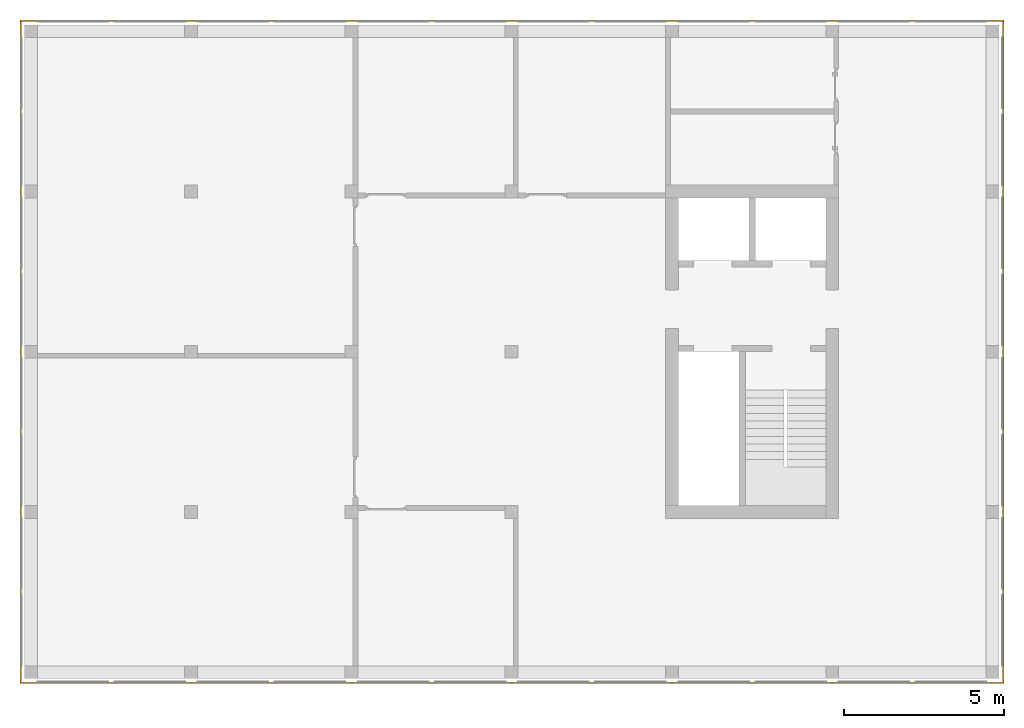
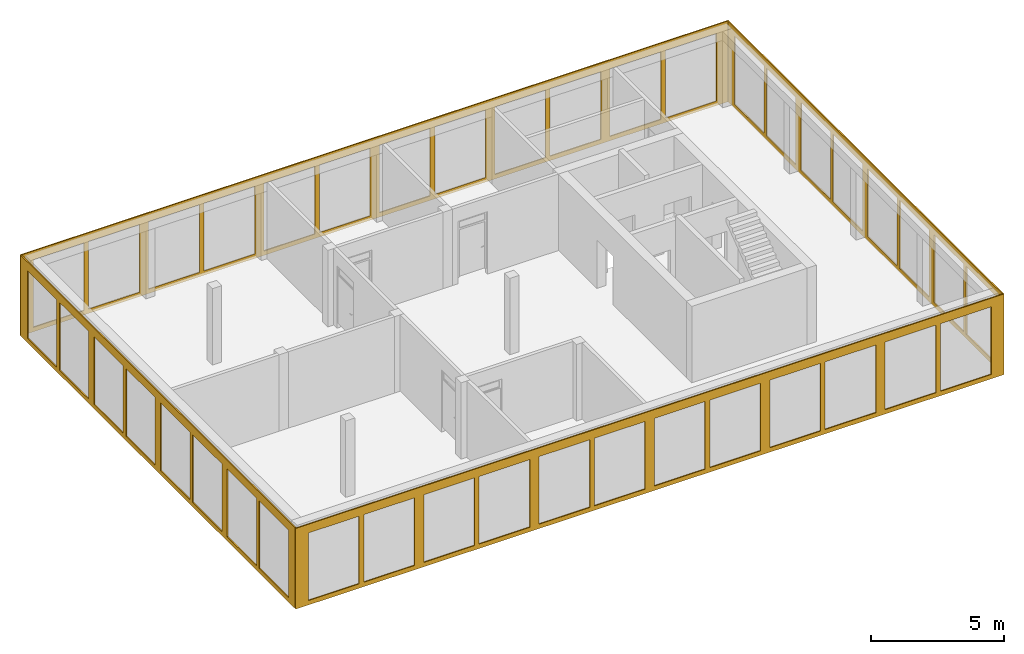
# One storey, part 6 of 6: 4 curtain walls.
"""IFC2X3 building model written with IfcOpenShell, lengths in metres."""

from ifc_helpers import new_model, entity, si_unit, converted_unit, frame, origin, place, context, subcontext, project, spatial, faceted_brep, material, element, save


model = new_model("IFC2X3")

# Units and contexts
model_context = context("Model", 3, precision=1e-05, world=origin())
body_context = subcontext(model_context, "Body", "Model", "MODEL_VIEW")
ifc_project = project(units=[si_unit("LENGTHUNIT", "METRE"), si_unit("AREAUNIT", "SQUARE_METRE"), si_unit("VOLUMEUNIT", "CUBIC_METRE"), si_unit("MASSUNIT", "GRAM", prefix="KILO"), converted_unit("PLANEANGLEUNIT", "DEGREE", entity("IfcPlaneAngleMeasure", 0.0174532925199433), si_unit("PLANEANGLEUNIT", "RADIAN"), dimensions=[0, 0, 0, 0, 0, 0, 0])], contexts=[model_context])

# Site, building, storey
site_placement = place(None, origin())
site = spatial("IfcSite", under=ifc_project, at=site_placement, CompositionType="ELEMENT")
building_placement = place(site_placement, origin())
building = spatial("IfcBuilding", under=site, at=building_placement, CompositionType="ELEMENT")
storey_placement = place(building_placement, frame((0.0, 0.0, 8.6)))
storey = spatial("IfcBuildingStorey", under=building, at=storey_placement, Name="2. Obergeschoss", CompositionType="ELEMENT", Elevation=8.6)

# Curtain walls
ifc_material_1 = material(Name="ALU")
curtain_wall_1_placement = place(storey_placement, frame((-0.139330706017223, 20.5, -0.2)))
element("IfcCurtainWall", 1, at=curtain_wall_1_placement, inside=storey, material=ifc_material_1, Name="Profil SN standard", context=body_context, shape_type="Brep", body=[
    faceted_brep([(0.0, 0.05, 3.7), (30.7, 0.05, 3.7), (30.7, 0.0, 3.7), (0.0, 0.0, 3.7), (30.7, 0.05, 0.0), (0.0, 0.05, 0.0), (0.0, 0.0, 0.0), (30.7, 0.0, 0.0), (27.95, 0.0, 0.2), (27.95, 0.0, 3.3), (27.95, 0.05, 3.3), (27.95, 0.05, 0.2), (27.75, 0.05, 0.2), (27.75, 0.05, 3.3), (27.75, 0.0, 3.3), (27.75, 0.0, 0.2), (22.95, 0.0, 0.2), (22.95, 0.0, 3.3), (22.95, 0.05, 3.3), (22.95, 0.05, 0.2), (22.75, 0.05, 0.2), (22.75, 0.05, 3.3), (22.75, 0.0, 3.3), (22.75, 0.0, 0.2), (17.75, 0.05, 0.2), (17.75, 0.05, 3.3), (17.75, 0.0, 3.3), (17.75, 0.0, 0.2), (17.95, 0.0, 0.2), (17.95, 0.0, 3.3), (17.95, 0.05, 3.3), (17.95, 0.05, 0.2), (25.15, 0.0, 0.2), (25.15, 0.05, 0.2), (25.15, 0.05, 3.3), (25.15, 0.0, 3.3), (25.55, 0.05, 0.2), (25.55, 0.0, 0.2), (25.55, 0.0, 3.3), (25.55, 0.05, 3.3), (20.15, 0.0, 0.2), (20.15, 0.05, 0.2), (20.15, 0.05, 3.3), (20.15, 0.0, 3.3), (20.55, 0.05, 0.2), (20.55, 0.0, 0.2), (20.55, 0.0, 3.3), (20.55, 0.05, 3.3), (30.15, 0.0, 0.2), (30.15, 0.05, 0.2), (30.15, 0.05, 3.3), (30.15, 0.0, 3.3), (2.75, 0.05, 0.2), (2.75, 0.05, 3.3), (2.75, 0.0, 3.3), (2.75, 0.0, 0.2), (2.95, 0.0, 0.2), (2.95, 0.0, 3.3), (2.95, 0.05, 3.3), (2.95, 0.05, 0.2), (12.75, 0.05, 0.2), (12.75, 0.05, 3.3), (12.75, 0.0, 3.3), (12.75, 0.0, 0.2), (12.95, 0.0, 0.2), (12.95, 0.0, 3.3), (12.95, 0.05, 3.3), (12.95, 0.05, 0.2), (7.75, 0.05, 0.2), (7.75, 0.05, 3.3), (7.75, 0.0, 3.3), (7.75, 0.0, 0.2), (7.95, 0.0, 0.2), (7.95, 0.0, 3.3), (7.95, 0.05, 3.3), (7.95, 0.05, 0.2), (15.55, 0.0, 0.2), (15.55, 0.05, 0.2), (15.55, 0.0, 3.3), (15.55, 0.05, 3.3), (10.55, 0.05, 3.3), (10.55, 0.0, 3.3), (15.15, 0.0, 3.3), (15.15, 0.05, 3.3), (15.15, 0.0, 0.2), (15.15, 0.05, 0.2), (10.55, 0.0, 0.2), (10.55, 0.05, 0.2), (0.550000000000002, 0.05, 3.3), (0.550000000000002, 0.0, 3.3), (5.15, 0.0, 3.3), (5.15, 0.05, 3.3), (5.15, 0.0, 0.2), (5.15, 0.05, 0.2), (0.550000000000002, 0.0, 0.2), (0.550000000000002, 0.05, 0.2), (5.55, 0.05, 0.2), (5.55, 0.0, 0.2), (5.55, 0.0, 3.3), (5.55, 0.05, 3.3), (10.15, 0.0, 3.3), (10.15, 0.05, 3.3), (10.15, 0.0, 0.2), (10.15, 0.05, 0.2)], [[[0, 1, 2, 3]], [[4, 5, 6, 7]], [[7, 2, 1, 4]], [[5, 0, 3, 6]], [[8, 9, 10, 11]], [[12, 13, 14, 15]], [[16, 17, 18, 19]], [[20, 21, 22, 23]], [[24, 25, 26, 27]], [[28, 29, 30, 31]], [[32, 33, 34, 35]], [[36, 37, 38, 39]], [[40, 41, 42, 43]], [[44, 45, 46, 47]], [[48, 49, 50, 51]], [[52, 53, 54, 55]], [[56, 57, 58, 59]], [[60, 61, 62, 63]], [[64, 65, 66, 67]], [[68, 69, 70, 71]], [[72, 73, 74, 75]], [[31, 41, 40, 28]], [[27, 76, 77, 24]], [[77, 76, 78, 79]], [[25, 79, 78, 26]], [[29, 43, 42, 30]], [[61, 80, 81, 62]], [[65, 82, 83, 66]], [[84, 85, 83, 82]], [[67, 85, 84, 64]], [[63, 86, 87, 60]], [[87, 86, 81, 80]], [[53, 88, 89, 54]], [[57, 90, 91, 58]], [[92, 93, 91, 90]], [[59, 93, 92, 56]], [[55, 94, 95, 52]], [[95, 94, 89, 88]], [[96, 97, 98, 99]], [[69, 99, 98, 70]], [[73, 100, 101, 74]], [[102, 103, 101, 100]], [[75, 103, 102, 72]], [[71, 97, 96, 68]], [[19, 33, 32, 16]], [[23, 45, 44, 20]], [[21, 47, 46, 22]], [[17, 35, 34, 18]], [[11, 49, 48, 8]], [[15, 37, 36, 12]], [[13, 39, 38, 14]], [[9, 51, 50, 10]], [[2, 7, 6, 3], [102, 100, 73, 72], [92, 90, 57, 56], [84, 82, 65, 64], [70, 98, 97, 71], [62, 81, 86, 63], [29, 28, 40, 43], [54, 89, 94, 55], [26, 78, 76, 27], [16, 32, 35, 17], [46, 45, 23, 22], [8, 48, 51, 9], [38, 37, 15, 14]], [[0, 5, 4, 1], [95, 88, 53, 52], [96, 99, 69, 68], [87, 80, 61, 60], [74, 101, 103, 75], [66, 83, 85, 67], [58, 91, 93, 59], [77, 79, 25, 24], [30, 42, 41, 31], [20, 44, 47, 21], [34, 33, 19, 18], [12, 36, 39, 13], [50, 49, 11, 10]]], orient=[[False], [False], [False], [False], [False], [False], [False], [False], [False], [False], [False], [False], [False], [False], [False], [False], [False], [False], [False], [False], [False], [False], [False], [False], [False], [False], [False], [False], [False], [False], [False], [False], [False], [False], [False], [False], [False], [False], [False], [False], [False], [False], [False], [False], [False], [False], [False], [False], [False], [False], [False], [False], [False, False, False, False, False, False, False, False, False, False, False, False, False], [False, False, False, False, False, False, False, False, False, False, False, False, False]]),
])
ifc_material_2 = material(Name="ALU")
curtain_wall_2_placement = place(storey_placement, frame((-0.139330706017223, -0.15, -0.2)))
element("IfcCurtainWall", 2, at=curtain_wall_2_placement, inside=storey, material=ifc_material_2, Name="Profil SN standard", context=body_context, shape_type="Brep", body=[
    faceted_brep([(30.7, 0.0500000000000003, 0.0), (0.0, 0.0500000000000003, 0.0), (0.0, 3.41060513164848e-16, 0.0), (30.7, 3.41060513164848e-16, 0.0), (0.0, 0.0500000000000004, 3.7), (30.7, 0.0500000000000003, 3.7), (30.7, 3.41060513164848e-16, 3.7), (0.0, 3.41060513164848e-16, 3.7), (25.15, 5.6843418860808e-17, 0.2), (25.15, 0.0500000000000001, 0.2), (25.15, 0.0500000000000001, 3.3), (25.15, 5.6843418860808e-17, 3.3), (25.55, 0.0500000000000001, 0.2), (25.55, 5.6843418860808e-17, 0.2), (25.55, 5.6843418860808e-17, 3.3), (25.55, 0.0500000000000001, 3.3), (20.15, 8.5265128291212e-17, 0.2), (20.15, 0.0500000000000001, 0.2), (20.15, 0.0500000000000001, 3.3), (20.15, 8.5265128291212e-17, 3.3), (20.55, 0.0500000000000001, 0.2), (20.55, 8.5265128291212e-17, 0.2), (20.55, 8.5265128291212e-17, 3.3), (20.55, 0.0500000000000001, 3.3), (30.15, 0.0, 0.2), (30.15, 0.05, 0.2), (30.15, 0.05, 3.3), (30.15, 0.0, 3.3), (22.75, 2.8421709430404e-16, 0.2), (22.75, 0.0500000000000003, 0.2), (22.75, 0.0500000000000003, 3.3), (22.75, 2.8421709430404e-16, 3.3), (22.95, 0.0500000000000003, 0.2), (22.95, 2.8421709430404e-16, 0.2), (22.95, 2.8421709430404e-16, 3.3), (22.95, 0.0500000000000003, 3.3), (17.75, 3.41060513164848e-16, 0.2), (17.75, 0.0500000000000003, 0.2), (17.75, 0.0500000000000003, 3.3), (17.75, 3.41060513164848e-16, 3.3), (17.95, 0.0500000000000003, 0.2), (17.95, 3.41060513164848e-16, 0.2), (17.95, 3.41060513164848e-16, 3.3), (17.95, 0.0500000000000003, 3.3), (27.75, 3.41060513164848e-16, 0.2), (27.75, 0.0500000000000003, 0.2), (27.75, 0.0500000000000003, 3.3), (27.75, 3.41060513164848e-16, 3.3), (27.95, 0.0500000000000003, 0.2), (27.95, 3.41060513164848e-16, 0.2), (27.95, 3.41060513164848e-16, 3.3), (27.95, 0.0500000000000003, 3.3), (2.75, 3.41060513164848e-16, 0.2), (2.75, 0.0500000000000003, 0.2), (2.75, 0.0500000000000003, 3.3), (2.75, 3.41060513164848e-16, 3.3), (2.95, 0.0500000000000003, 0.2), (2.95, 3.41060513164848e-16, 0.2), (2.95, 3.41060513164848e-16, 3.3), (2.95, 0.0500000000000003, 3.3), (12.75, 3.41060513164848e-16, 0.2), (12.75, 0.0500000000000003, 0.2), (12.75, 0.0500000000000003, 3.3), (12.75, 3.41060513164848e-16, 3.3), (12.95, 0.0500000000000003, 0.2), (12.95, 3.41060513164848e-16, 0.2), (12.95, 3.41060513164848e-16, 3.3), (12.95, 0.0500000000000003, 3.3), (7.75, 3.41060513164848e-16, 0.2), (7.75, 0.0500000000000003, 0.2), (7.75, 0.0500000000000003, 3.3), (7.75, 3.41060513164848e-16, 3.3), (7.95, 0.0500000000000003, 0.2), (7.95, 3.41060513164848e-16, 0.2), (7.95, 3.41060513164848e-16, 3.3), (7.95, 0.0500000000000003, 3.3), (15.55, 3.41060513164848e-16, 0.2), (15.55, 0.0500000000000003, 0.2), (15.55, 3.41060513164848e-16, 3.3), (15.55, 0.0500000000000003, 3.3), (10.55, 0.0500000000000002, 3.3), (10.55, 1.70530256582424e-16, 3.3), (15.15, 3.41060513164848e-16, 3.3), (15.15, 0.0500000000000003, 3.3), (15.15, 3.41060513164848e-16, 0.2), (15.15, 0.0500000000000003, 0.2), (10.55, 3.41060513164848e-16, 0.2), (10.55, 0.0500000000000003, 0.2), (0.550000000000004, 0.0500000000000003, 3.3), (0.550000000000004, 2.8421709430404e-16, 3.3), (5.15, 2.27373675443232e-16, 3.3), (5.15, 0.0500000000000003, 3.3), (5.15, 3.41060513164848e-16, 0.2), (5.15, 0.0500000000000003, 0.2), (0.550000000000004, 2.8421709430404e-16, 0.2), (0.550000000000004, 0.0500000000000003, 0.2), (5.55, 0.0500000000000003, 0.2), (5.55, 3.41060513164848e-16, 0.2), (5.55, 2.27373675443232e-16, 3.3), (5.55, 0.0500000000000003, 3.3), (10.15, 1.70530256582424e-16, 3.3), (10.15, 0.0500000000000002, 3.3), (10.15, 3.41060513164848e-16, 0.2), (10.15, 0.0500000000000003, 0.2)], [[[0, 1, 2, 3]], [[4, 5, 6, 7]], [[3, 6, 5, 0]], [[1, 4, 7, 2]], [[8, 9, 10, 11]], [[12, 13, 14, 15]], [[16, 17, 18, 19]], [[20, 21, 22, 23]], [[24, 25, 26, 27]], [[28, 29, 30, 31]], [[32, 33, 34, 35]], [[36, 37, 38, 39]], [[40, 41, 42, 43]], [[44, 45, 46, 47]], [[48, 49, 50, 51]], [[52, 53, 54, 55]], [[56, 57, 58, 59]], [[60, 61, 62, 63]], [[64, 65, 66, 67]], [[68, 69, 70, 71]], [[72, 73, 74, 75]], [[36, 76, 77, 37]], [[77, 76, 78, 79]], [[38, 79, 78, 39]], [[62, 80, 81, 63]], [[66, 82, 83, 67]], [[84, 85, 83, 82]], [[64, 85, 84, 65]], [[60, 86, 87, 61]], [[87, 86, 81, 80]], [[54, 88, 89, 55]], [[58, 90, 91, 59]], [[92, 93, 91, 90]], [[56, 93, 92, 57]], [[52, 94, 95, 53]], [[95, 94, 89, 88]], [[96, 97, 98, 99]], [[70, 99, 98, 71]], [[74, 100, 101, 75]], [[102, 103, 101, 100]], [[72, 103, 102, 73]], [[68, 97, 96, 69]], [[16, 41, 40, 17]], [[20, 29, 28, 21]], [[8, 33, 32, 9]], [[12, 45, 44, 13]], [[22, 31, 30, 23]], [[18, 43, 42, 19]], [[14, 47, 46, 15]], [[10, 35, 34, 11]], [[24, 49, 48, 25]], [[26, 51, 50, 27]], [[6, 3, 2, 7], [97, 68, 71, 98], [89, 94, 52, 55], [81, 86, 60, 63], [73, 102, 100, 74], [65, 84, 82, 66], [57, 92, 90, 58], [78, 76, 36, 39], [27, 50, 49, 24], [21, 28, 31, 22], [42, 41, 16, 19], [13, 44, 47, 14], [34, 33, 8, 11]], [[4, 1, 0, 5], [93, 56, 59, 91], [101, 103, 72, 75], [85, 64, 67, 83], [69, 96, 99, 70], [61, 87, 80, 62], [53, 95, 88, 54], [37, 77, 79, 38], [25, 48, 51, 26], [17, 40, 43, 18], [30, 29, 20, 23], [9, 32, 35, 10], [46, 45, 12, 15]]], orient=[[False], [False], [False], [False], [False], [False], [False], [False], [False], [False], [False], [False], [False], [False], [False], [False], [False], [False], [False], [False], [False], [False], [False], [False], [False], [False], [False], [False], [False], [False], [False], [False], [False], [False], [False], [False], [False], [False], [False], [False], [False], [False], [False], [False], [False], [False], [False], [False], [False], [False], [False], [False], [False, False, False, False, False, False, False, False, False, False, False, False, False], [False, False, False, False, False, False, False, False, False, False, False, False, False]]),
])
ifc_material_3 = material(Name="ALU")
curtain_wall_3_placement = place(storey_placement, frame((30.5106692939828, -0.1, -0.2)))
element("IfcCurtainWall", 3, at=curtain_wall_3_placement, inside=storey, material=ifc_material_3, Name="Profil OW standard", context=body_context, shape_type="Brep", body=[
    faceted_brep([(0.05, 20.6, 3.7), (0.05, 0.0, 3.7), (0.0, 0.0, 3.7), (0.0, 20.6, 3.7), (0.05, 0.0, 0.0), (0.05, 20.6, 0.0), (0.0, 20.6, 0.0), (0.0, 0.0, 0.0), (3.63797880709171e-15, 0.500000000000022, 0.2), (0.0500000000000036, 0.500000000000022, 0.2), (0.0500000000000036, 0.500000000000022, 3.3), (3.63797880709171e-15, 0.500000000000022, 3.3), (0.05, 2.70000000000003, 0.2), (0.0, 2.70000000000003, 0.2), (0.0, 2.70000000000003, 3.3), (0.05, 2.70000000000003, 3.3), (0.05, 2.90000000000003, 0.2), (0.05, 2.90000000000003, 3.3), (0.0, 2.90000000000003, 3.3), (0.0, 2.90000000000003, 0.2), (0.0, 7.70000000000003, 0.2), (0.0, 7.70000000000003, 3.3), (0.05, 7.70000000000003, 3.3), (0.05, 7.70000000000003, 0.2), (0.05, 7.90000000000003, 0.2), (0.05, 7.90000000000003, 3.3), (0.0, 7.90000000000003, 3.3), (0.0, 7.90000000000003, 0.2), (0.0, 12.7, 0.2), (0.0, 12.7, 3.3), (0.05, 12.7, 3.3), (0.05, 12.7, 0.2), (0.05, 12.9, 0.2), (0.05, 12.9, 3.3), (0.0, 12.9, 3.3), (0.0, 12.9, 0.2), (0.0, 5.50000000000002, 0.2), (0.05, 5.50000000000002, 0.2), (0.05, 5.10000000000002, 0.2), (0.0, 5.10000000000002, 0.2), (0.0, 5.10000000000002, 3.3), (0.05, 5.10000000000002, 3.3), (0.05, 5.50000000000002, 3.3), (0.0, 5.50000000000002, 3.3), (0.0, 10.5, 0.2), (0.05, 10.5, 0.2), (0.05, 10.1, 0.2), (0.0, 10.1, 0.2), (0.0, 10.1, 3.3), (0.05, 10.1, 3.3), (0.05, 10.5, 3.3), (0.0, 10.5, 3.3), (0.05, 15.1, 0.2), (0.0, 15.1, 0.2), (0.0, 15.1, 3.3), (0.05, 15.1, 3.3), (0.0, 15.5, 0.2), (0.05, 15.5, 0.2), (0.05, 15.5, 3.3), (0.0, 15.5, 3.3), (0.05, 20.1, 0.2), (0.0, 20.1, 0.2), (0.0, 20.1, 3.3), (0.05, 20.1, 3.3), (0.05, 17.7, 0.2), (0.0, 17.7, 0.2), (0.0, 17.9, 0.2), (0.05, 17.9, 0.2), (0.05, 17.9, 3.3), (0.0, 17.9, 3.3), (0.0, 17.7, 3.3), (0.05, 17.7, 3.3)], [[[0, 1, 2, 3]], [[4, 5, 6, 7]], [[8, 9, 10, 11]], [[7, 2, 1, 4]], [[12, 9, 8, 13]], [[14, 11, 10, 15]], [[13, 14, 15, 12]], [[16, 17, 18, 19]], [[20, 21, 22, 23]], [[24, 25, 26, 27]], [[28, 29, 30, 31]], [[32, 33, 34, 35]], [[36, 20, 23, 37]], [[38, 16, 19, 39]], [[40, 18, 17, 41]], [[42, 22, 21, 43]], [[36, 37, 42, 43]], [[38, 39, 40, 41]], [[44, 28, 31, 45]], [[46, 24, 27, 47]], [[48, 26, 25, 49]], [[50, 30, 29, 51]], [[44, 45, 50, 51]], [[46, 47, 48, 49]], [[52, 32, 35, 53]], [[54, 34, 33, 55]], [[56, 57, 58, 59]], [[52, 53, 54, 55]], [[5, 0, 3, 6]], [[60, 61, 62, 63]], [[64, 57, 56, 65]], [[66, 61, 60, 67]], [[68, 63, 62, 69]], [[70, 59, 58, 71]], [[65, 70, 71, 64]], [[67, 68, 69, 66]], [[2, 7, 6, 3], [13, 8, 11, 14], [39, 19, 18, 40], [21, 20, 36, 43], [47, 27, 26, 48], [29, 28, 44, 51], [53, 35, 34, 54], [65, 56, 59, 70], [62, 61, 66, 69]], [[4, 1, 0, 5], [15, 10, 9, 12], [41, 17, 16, 38], [23, 22, 42, 37], [49, 25, 24, 46], [31, 30, 50, 45], [33, 32, 52, 55], [67, 60, 63, 68], [58, 57, 64, 71]]], orient=[[False], [False], [False], [False], [False], [False], [False], [False], [False], [False], [False], [False], [False], [False], [False], [False], [False], [False], [False], [False], [False], [False], [False], [False], [False], [False], [False], [False], [False], [False], [False], [False], [False], [False], [False], [False], [False, False, False, False, False, False, False, False, False], [False, False, False, False, False, False, False, False, False]]),
])
ifc_material_4 = material(Name="ALU")
curtain_wall_4_placement = place(storey_placement, frame((-0.139330706017224, -0.1, -0.2)))
element("IfcCurtainWall", 4, at=curtain_wall_4_placement, inside=storey, material=ifc_material_4, Name="Profil OW standard", context=body_context, shape_type="Brep", body=[
    faceted_brep([(0.0500000000000026, 0.0, 0.0), (0.0500000000000026, 20.6, 0.0), (2.55795384873636e-15, 20.6, 0.0), (2.58637555816676e-15, 0.0, 0.0), (0.0500000000000026, 20.6, 3.7), (0.0500000000000026, 0.0, 3.7), (2.58637555816676e-15, 0.0, 3.7), (2.55795384873636e-15, 20.6, 3.7), (0.0500000000000012, 10.1, 0.2), (1.10844666778576e-15, 10.1, 0.2), (1.10844666778576e-15, 10.1, 3.3), (0.0500000000000012, 10.1, 3.3), (1.08002495835535e-15, 10.5, 0.2), (0.0500000000000011, 10.5, 0.2), (0.0500000000000011, 10.5, 3.3), (1.08002495835535e-15, 10.5, 3.3), (1.62003743753303e-15, 5.50000000000002, 0.2), (0.0500000000000017, 5.50000000000002, 0.2), (0.0500000000000017, 5.50000000000002, 3.3), (1.62003743753303e-15, 5.50000000000002, 3.3), (0.0500000000000017, 5.10000000000002, 0.2), (1.67688085639384e-15, 5.10000000000002, 0.2), (1.67688085639384e-15, 5.10000000000002, 3.3), (0.0500000000000017, 5.10000000000002, 3.3), (5.11590769747272e-16, 15.5, 0.2), (0.0500000000000005, 15.5, 0.2), (0.0500000000000005, 15.5, 3.3), (5.11590769747272e-16, 15.5, 3.3), (0.0500000000000006, 15.1, 0.2), (5.6843418860808e-16, 15.1, 0.2), (5.6843418860808e-16, 15.1, 3.3), (0.0500000000000006, 15.1, 3.3), (0.05, 20.1, 0.2), (0.0, 20.1, 0.2), (0.0, 20.1, 3.3), (0.05, 20.1, 3.3), (2.18847162614111e-15, 7.90000000000002, 0.2), (0.0500000000000022, 7.90000000000002, 0.2), (0.0500000000000022, 7.90000000000002, 3.3), (2.18847162614111e-15, 7.90000000000002, 3.3), (0.0500000000000023, 7.70000000000002, 0.2), (2.24531504500192e-15, 7.70000000000002, 0.2), (2.24531504500192e-15, 7.70000000000002, 3.3), (0.0500000000000023, 7.70000000000002, 3.3), (2.18847162614111e-15, 2.90000000000002, 0.2), (0.0500000000000022, 2.90000000000002, 0.2), (0.0500000000000022, 2.90000000000002, 3.3), (2.18847162614111e-15, 2.90000000000002, 3.3), (0.0500000000000023, 2.70000000000002, 0.2), (2.24531504500192e-15, 2.70000000000002, 0.2), (2.24531504500192e-15, 2.70000000000002, 3.3), (0.0500000000000023, 2.70000000000002, 3.3), (2.18847162614111e-15, 17.9, 0.2), (0.0500000000000022, 17.9, 0.2), (0.0500000000000022, 17.9, 3.3), (2.18847162614111e-15, 17.9, 3.3), (0.0500000000000023, 17.7, 0.2), (2.24531504500192e-15, 17.7, 0.2), (2.24531504500192e-15, 17.7, 3.3), (0.0500000000000023, 17.7, 3.3), (2.24531504500192e-15, 12.7, 3.3), (0.0500000000000023, 12.7, 3.3), (2.18847162614111e-15, 12.9, 3.3), (0.0500000000000022, 12.9, 3.3), (0.0500000000000022, 12.9, 0.2), (2.18847162614111e-15, 12.9, 0.2), (0.0500000000000023, 12.7, 0.2), (2.24531504500192e-15, 12.7, 0.2), (0.0500000000000026, 0.500000000000022, 0.2), (2.58637555816676e-15, 0.500000000000022, 0.2), (0.0500000000000026, 0.500000000000022, 3.3), (2.58637555816676e-15, 0.500000000000022, 3.3)], [[[0, 1, 2, 3]], [[4, 5, 6, 7]], [[8, 9, 10, 11]], [[12, 13, 14, 15]], [[3, 6, 5, 0]], [[16, 17, 18, 19]], [[20, 21, 22, 23]], [[1, 4, 7, 2]], [[24, 25, 26, 27]], [[28, 29, 30, 31]], [[32, 33, 34, 35]], [[36, 37, 38, 39]], [[40, 41, 42, 43]], [[44, 45, 46, 47]], [[48, 49, 50, 51]], [[52, 53, 54, 55]], [[56, 57, 58, 59]], [[60, 15, 14, 61]], [[30, 62, 63, 31]], [[26, 59, 58, 27]], [[34, 55, 54, 35]], [[32, 53, 52, 33]], [[24, 57, 56, 25]], [[28, 64, 65, 29]], [[66, 13, 12, 67]], [[36, 9, 8, 37]], [[16, 41, 40, 17]], [[20, 45, 44, 21]], [[48, 68, 69, 49]], [[69, 68, 70, 71]], [[50, 71, 70, 51]], [[22, 47, 46, 23]], [[18, 43, 42, 19]], [[38, 11, 10, 39]], [[65, 64, 63, 62]], [[66, 67, 60, 61]], [[2, 7, 6, 3], [69, 71, 50, 49], [39, 10, 9, 36], [33, 52, 55, 34], [29, 65, 62, 30], [58, 57, 24, 27], [19, 42, 41, 16], [44, 47, 22, 21], [60, 67, 12, 15]], [[0, 5, 4, 1], [51, 70, 68, 48], [13, 66, 61, 14], [35, 54, 53, 32], [31, 63, 64, 28], [56, 59, 26, 25], [23, 46, 45, 20], [40, 43, 18, 17], [38, 37, 8, 11]]], orient=[[False], [False], [False], [False], [False], [False], [False], [False], [False], [False], [False], [False], [False], [False], [False], [False], [False], [False], [False], [False], [False], [False], [False], [False], [False], [False], [False], [False], [False], [False], [False], [False], [False], [False], [False], [False], [False, False, False, False, False, False, False, False, False], [False, False, False, False, False, False, False, False, False]]),
])

save(model, "model.ifc")
